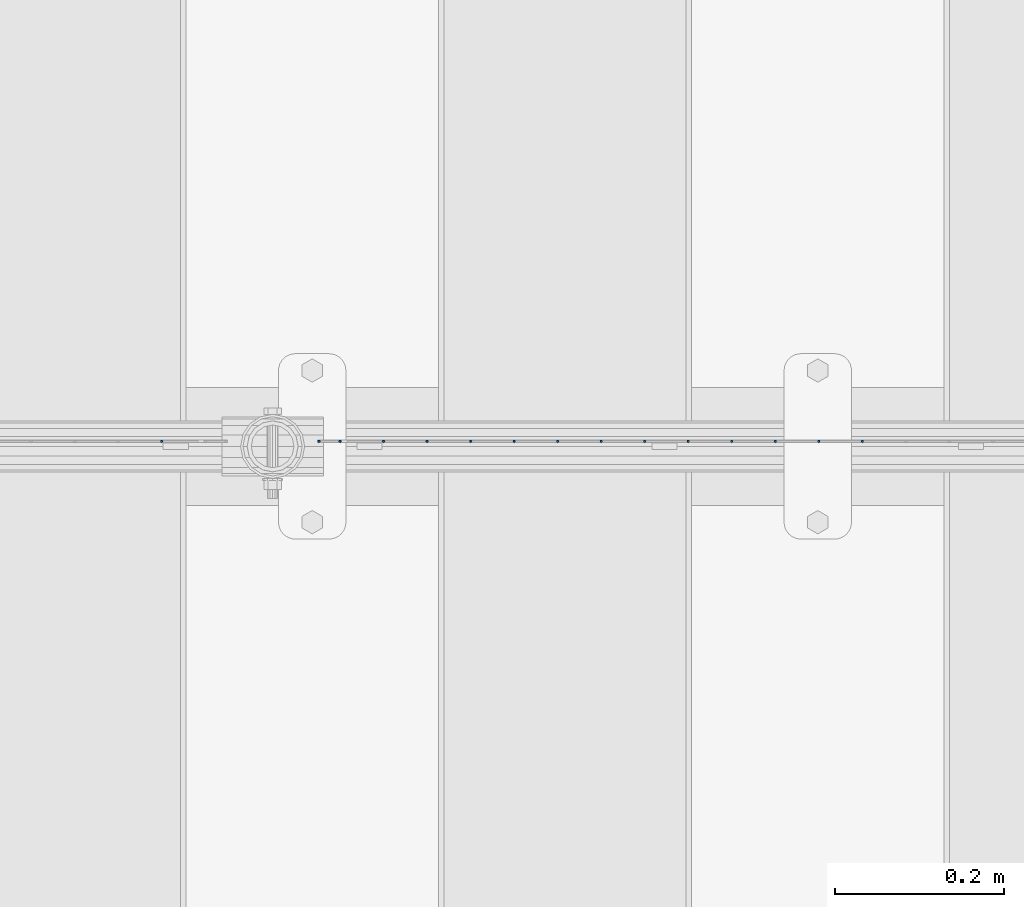
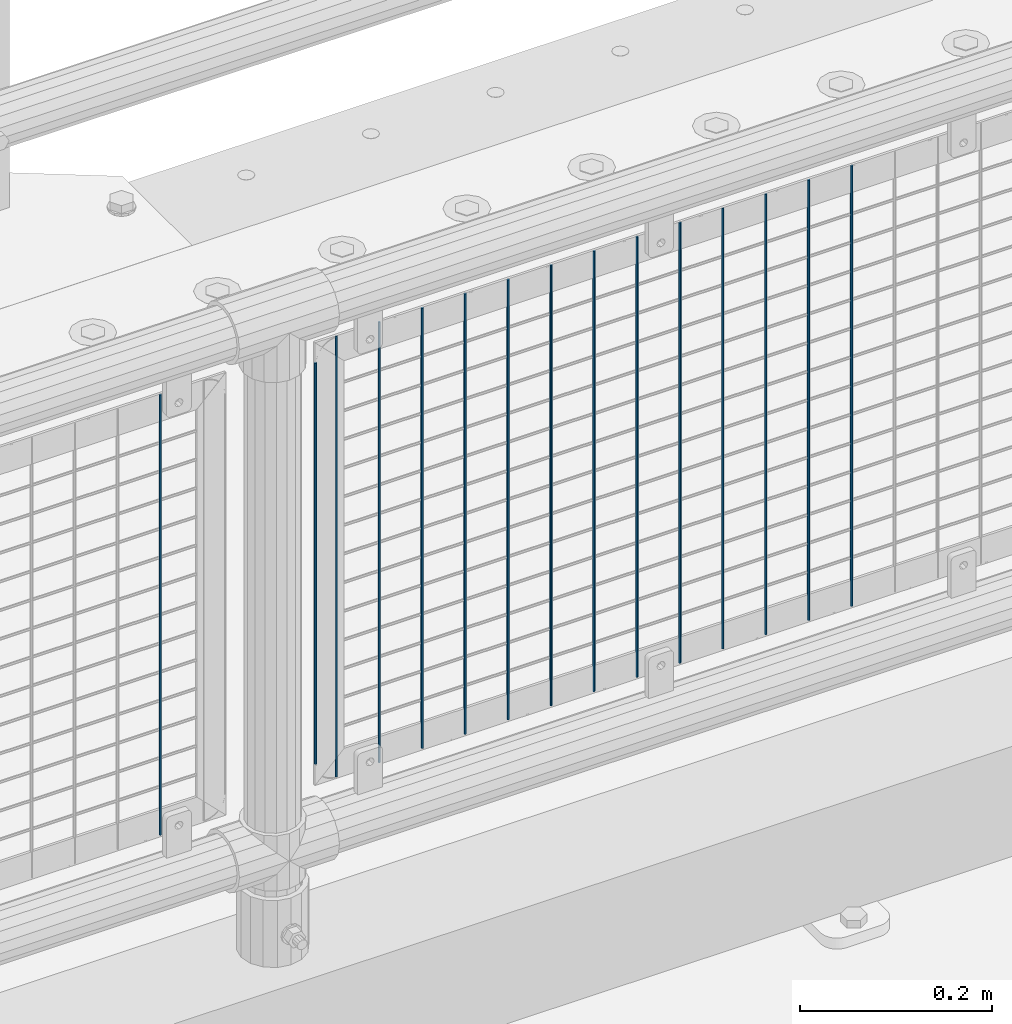
# One storey, part 68 of 193: 15 columns.
"""IFC2X3 building model written with IfcOpenShell, lengths in millimetres."""

from ifc_helpers import new_model, si_unit, frame, origin_with_axes, place, context, subcontext, project, spatial, faceted_brep, material, type_object, element, save


model = new_model("IFC2X3")

# Units and contexts
model_context = context("Model", 3, precision=1e-05, world=origin_with_axes())
body_context = subcontext(model_context, "Body", "Model", "MODEL_VIEW")
ifc_project = project(units=[si_unit("LENGTHUNIT", "METRE", prefix="MILLI"), si_unit("AREAUNIT", "SQUARE_METRE"), si_unit("VOLUMEUNIT", "CUBIC_METRE"), si_unit("MASSUNIT", "GRAM", prefix="KILO"), si_unit("TIMEUNIT", "SECOND"), si_unit("PLANEANGLEUNIT", "RADIAN"), si_unit("SOLIDANGLEUNIT", "STERADIAN"), si_unit("THERMODYNAMICTEMPERATUREUNIT", "DEGREE_CELSIUS"), si_unit("LUMINOUSINTENSITYUNIT", "LUMEN")], contexts=[model_context])

# Site, building, storey
site_placement = place(None, origin_with_axes())
site = spatial("IfcSite", under=ifc_project, at=site_placement, CompositionType="ELEMENT")
building_placement = place(site_placement, origin_with_axes())
building = spatial("IfcBuilding", under=site, at=building_placement, Name="Standard", CompositionType="ELEMENT")
storey_placement = place(building_placement, origin_with_axes())
storey = spatial("IfcBuildingStorey", under=building, at=storey_placement, Name="Undefined", CompositionType="ELEMENT", Elevation=0.0)

# Columns
ifc_material = material(Name="Misc_Undefined")
column_type = type_object("IfcColumnType", Name="D3", PredefinedType="NOTDEFINED")
for number, where, z_axis, x_axis in (
    (1, (-34497.14, 28670.5, 353.020000000001), (-1.0, 0.0, 0.0), (0.0, 0.0, 1.0)),
    (2, (-34548.795, 28670.5, 353.020000000001), (-1.0, 0.0, 0.0), (0.0, 0.0, 1.0)),
    (3, (-34600.45, 28670.5, 353.020000000001), (-1.0, 0.0, 0.0), (0.0, 0.0, 1.0)),
    (4, (-34652.105, 28670.5, 353.020000000001), (-1.0, 0.0, 0.0), (0.0, 0.0, 1.0)),
    (5, (-34703.76, 28670.5, 353.020000000001), (-1.0, 0.0, 0.0), (0.0, 0.0, 1.0)),
    (6, (-34755.415, 28670.5, 353.020000000001), (-1.0, 0.0, 0.0), (0.0, 0.0, 1.0)),
    (7, (-34807.07, 28670.5, 353.020000000001), (-1.0, 0.0, 0.0), (0.0, 0.0, 1.0)),
    (8, (-34858.725, 28670.5, 353.020000000001), (-1.0, 0.0, 0.0), (0.0, 0.0, 1.0)),
    (9, (-34910.38, 28670.5, 353.020000000001), (-1.0, 0.0, 0.0), (0.0, 0.0, 1.0)),
    (10, (-34962.035, 28670.5, 353.020000000001), (-1.0, 0.0, 0.0), (0.0, 0.0, 1.0)),
    (11, (-35013.69, 28670.5, 353.020000000001), (-1.0, 0.0, 0.0), (0.0, 0.0, 1.0)),
    (12, (-35065.345, 28670.5, 353.020000000001), (-1.0, 0.0, 0.0), (0.0, 0.0, 1.0)),
):
    element("IfcColumn", number, at=place(storey_placement, frame(where, z_axis=z_axis, x_axis=x_axis)), inside=storey, type_object=column_type, material=ifc_material, ObjectType="D3", context=body_context, shape_type="Brep", body=[
        faceted_brep([(0.0, -1.49999999999636, 3.63797880709171e-12), (0.0, -0.75, -1.29903810567669), (560.0, -0.75, -1.29903810567703), (560.0, -1.5, 0.0), (0.0, 0.75, -1.29903810567669), (560.0, 0.75, -1.29903810567703), (0.0, 1.50000000000364, 7.27595761418343e-12), (560.0, 1.5, 0.0), (0.0, 0.75, 1.29903810567669), (560.0, 0.75, 1.29903810567703), (0.0, -0.75, 1.29903810567669), (560.0, -0.75, 1.29903810567703)], [[[0, 1, 2, 3]], [[1, 4, 5, 2]], [[4, 6, 7, 5]], [[6, 8, 9, 7]], [[8, 10, 11, 9]], [[10, 0, 3, 11]], [[5, 7, 9, 11, 3, 2]], [[10, 8, 6, 4, 1, 0]]]),
    ])
column_placement = place(storey_placement, frame((-35142.0, 28670.5, 378.020000000001), z_axis=(-1.0, 0.0, 0.0), x_axis=(0.0, 0.0, 1.0)))
element("IfcColumn", 13, at=column_placement, inside=storey, type_object=column_type, material=ifc_material, ObjectType="D3", context=body_context, shape_type="Brep", body=[
    faceted_brep([(0.0, -1.49999999999636, 3.63797880709171e-12), (0.0, -0.75, -1.29903810567669), (510.0, -0.75, -1.29903810567703), (510.0, -1.5, 0.0), (0.0, 0.75, -1.29903810567669), (510.0, 0.75, -1.29903810567703), (0.0, 1.50000000000364, 7.27595761418343e-12), (510.0, 1.5, 0.0), (0.0, 0.75, 1.29903810567669), (510.0, 0.75, 1.29903810567703), (0.0, -0.75, 1.29903810567669), (510.0, -0.75, 1.29903810567703)], [[[0, 1, 2, 3]], [[1, 4, 5, 2]], [[4, 6, 7, 5]], [[6, 8, 9, 7]], [[8, 10, 11, 9]], [[10, 0, 3, 11]], [[5, 7, 9, 11, 3, 2]], [[10, 8, 6, 4, 1, 0]]]),
])
for number, where, z_axis, x_axis in (
    (14, (-35117.0, 28670.5, 353.020000000001), (-1.0, 0.0, 0.0), (0.0, 0.0, 1.0)),
    (15, (-35328.66, 28670.5, 353.02), (-1.0, 0.0, 0.0), (0.0, 0.0, 1.0)),
):
    element("IfcColumn", number, at=place(storey_placement, frame(where, z_axis=z_axis, x_axis=x_axis)), inside=storey, type_object=column_type, material=ifc_material, ObjectType="D3", context=body_context, shape_type="Brep", body=[
        faceted_brep([(0.0, -1.49999999999636, 3.63797880709171e-12), (0.0, -0.75, -1.29903810567669), (560.0, -0.75, -1.29903810567703), (560.0, -1.5, 0.0), (0.0, 0.75, -1.29903810567669), (560.0, 0.75, -1.29903810567703), (0.0, 1.50000000000364, 7.27595761418343e-12), (560.0, 1.5, 0.0), (0.0, 0.75, 1.29903810567669), (560.0, 0.75, 1.29903810567703), (0.0, -0.75, 1.29903810567669), (560.0, -0.75, 1.29903810567703)], [[[0, 1, 2, 3]], [[1, 4, 5, 2]], [[4, 6, 7, 5]], [[6, 8, 9, 7]], [[8, 10, 11, 9]], [[10, 0, 3, 11]], [[5, 7, 9, 11, 3, 2]], [[10, 8, 6, 4, 1, 0]]]),
    ])

save(model, "model.ifc")
